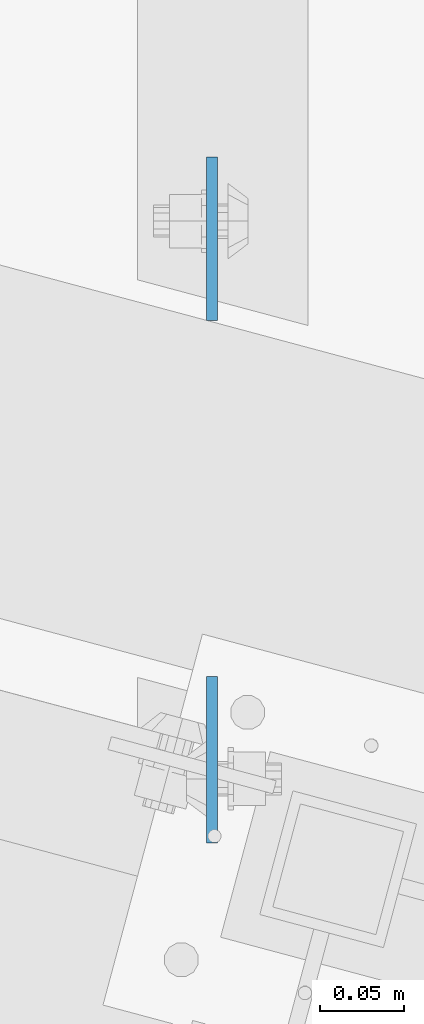
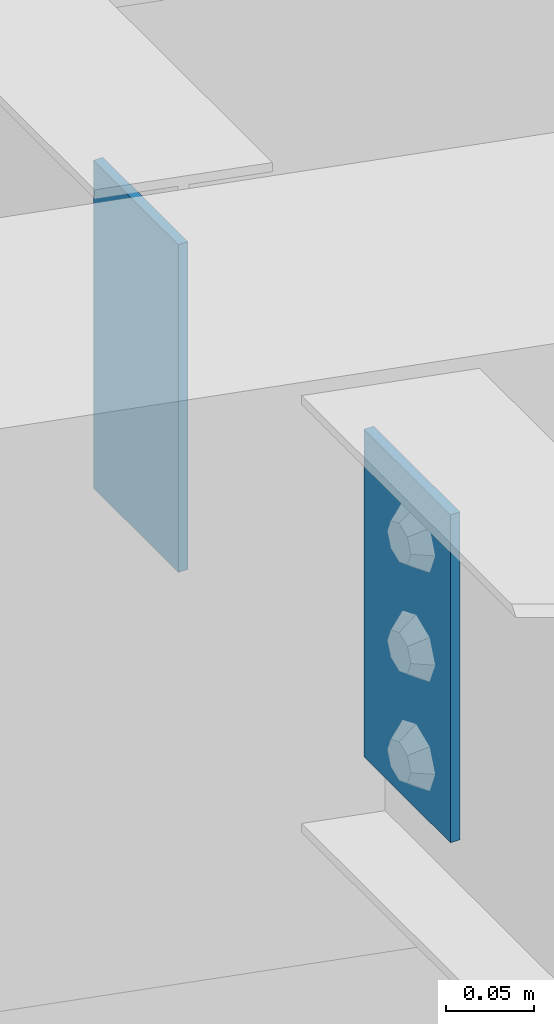
# One storey, part 1695 of 1763: 2 plates, 1 element without a shape of its own.
"""IFC2X3 building model written with IfcOpenShell, lengths in millimetres."""

from ifc_helpers import new_model, si_unit, frame, origin_with_axes, place, context, subcontext, project, spatial, faceted_brep, material, type_object, element, aggregate, save


model = new_model("IFC2X3")

# Units and contexts
model_context = context("Model", 3, precision=1e-05, world=origin_with_axes())
body_context = subcontext(model_context, "Body", "Model", "MODEL_VIEW")
ifc_project = project(units=[si_unit("LENGTHUNIT", "METRE", prefix="MILLI"), si_unit("AREAUNIT", "SQUARE_METRE"), si_unit("VOLUMEUNIT", "CUBIC_METRE"), si_unit("MASSUNIT", "GRAM", prefix="KILO"), si_unit("TIMEUNIT", "SECOND"), si_unit("PLANEANGLEUNIT", "RADIAN"), si_unit("SOLIDANGLEUNIT", "STERADIAN"), si_unit("THERMODYNAMICTEMPERATUREUNIT", "DEGREE_CELSIUS"), si_unit("LUMINOUSINTENSITYUNIT", "LUMEN")], contexts=[model_context])

# Site, building, storey
site_placement = place(None, origin_with_axes())
site = spatial("IfcSite", under=ifc_project, at=site_placement, CompositionType="ELEMENT")
building_placement = place(site_placement, origin_with_axes())
building = spatial("IfcBuilding", under=site, at=building_placement, Name="Undefined", CompositionType="ELEMENT")
storey_placement = place(building_placement, origin_with_axes())
storey = spatial("IfcBuildingStorey", under=building, at=storey_placement, Name="Undefined", CompositionType="ELEMENT", Elevation=0.0)

# Assembly, plates
assembly_placement = place(storey_placement, origin_with_axes())
assembly = element("IfcElementAssembly", 1, at=assembly_placement, inside=storey, Name="BEAM", AssemblyPlace="NOTDEFINED", PredefinedType="RIGID_FRAME")
ifc_material = material(Name="STEEL/A36")
plate_type_1 = type_object("IfcPlateType", PredefinedType="NOTDEFINED")
plate_1_placement = place(assembly_placement, frame((-27694.919617458, 63578.110750125, 12407.9), z_axis=(0.0, 1.0, 0.0), x_axis=(0.0, 0.0, -1.0)))
plate_1 = element("IfcPlate", 2, at=plate_1_placement, type_object=plate_type_1, material=ifc_material, Name="PLATE", context=body_context, shape_type="Brep", body=[
    faceted_brep([(1.81898940354586e-12, -3.17500000000291, 0.0), (0.0, -3.17499999999927, 97.1715316772461), (0.0, 3.17499999999927, 97.1715316772461), (-1.81898940354586e-12, 3.17499999997381, 0.0), (228.600006103516, -3.17499999999927, 97.1715316772461), (228.600006103516, 3.17499999999927, 97.1715316772461), (228.600006103516, -3.17500000001019, -7.27595761418343e-12), (228.600006103516, 3.17499999999563, -7.27595761418343e-12)], [[[0, 1, 2, 3]], [[1, 4, 5, 2]], [[4, 6, 7, 5]], [[6, 0, 3, 7]], [[5, 7, 3, 2]], [[6, 4, 1, 0]]]),
])
plate_type_2 = type_object("IfcPlateType", PredefinedType="NOTDEFINED")
plate_2_placement = place(assembly_placement, frame((-27694.9196174578, 63366.0411528934, 12407.9), z_axis=(0.0, -1.0, 0.0), x_axis=(0.0, 0.0, -1.0)))
plate_2 = element("IfcPlate", 3, at=plate_2_placement, type_object=plate_type_2, material=ifc_material, Name="PLATE", context=body_context, shape_type="Brep", body=[
    faceted_brep([(1.81898940354586e-12, -3.17500000000291, 0.0), (0.0, -3.17500000000291, 98.8730087280273), (0.0, 3.17500000000291, 98.8730087280273), (-1.81898940354586e-12, 3.17499999997381, 0.0), (228.600006103516, -3.17500000000291, 98.8730087280273), (228.600006103516, 3.17500000000291, 98.8730087280273), (228.600006103516, -3.17500000001019, -7.27595761418343e-12), (228.600006103516, 3.17499999999563, -7.27595761418343e-12)], [[[0, 1, 2, 3]], [[1, 4, 5, 2]], [[4, 6, 7, 5]], [[6, 0, 3, 7]], [[5, 7, 3, 2]], [[6, 4, 1, 0]]]),
])
aggregate(assembly, [plate_1, plate_2])

save(model, "model.ifc")
